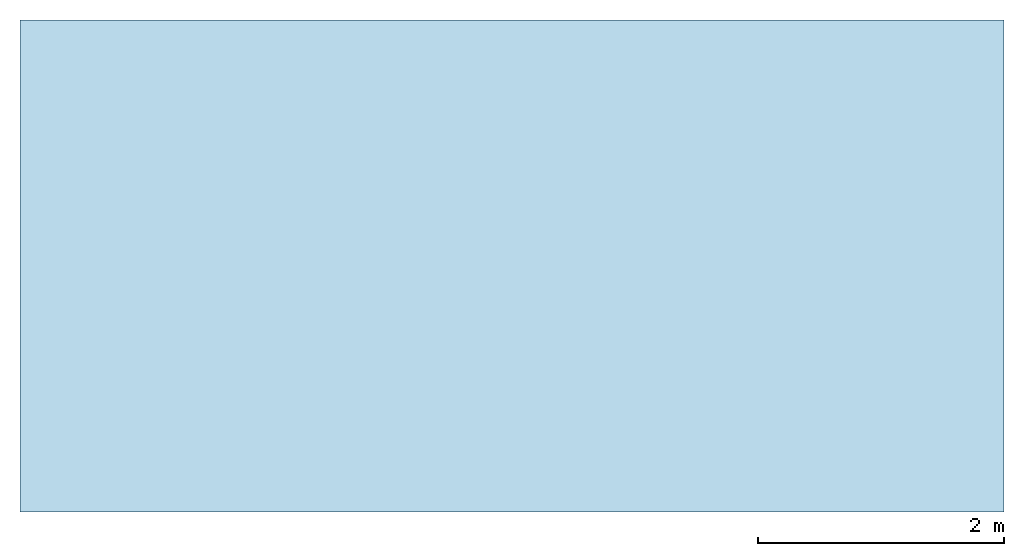
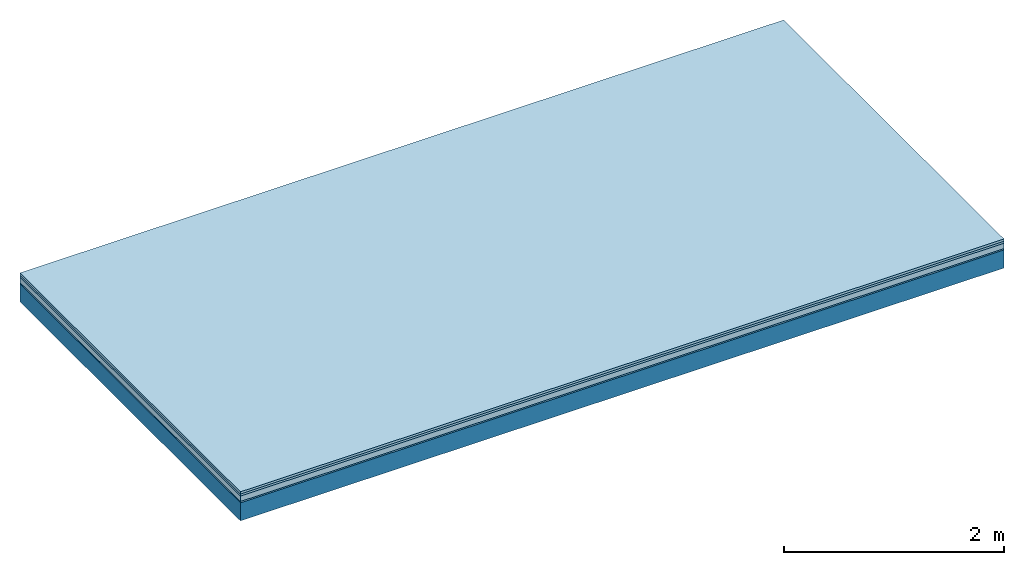
# One storey: 4 plates, 1 member, 1 element without a shape of its own.
"""IFC4 building model written with IfcOpenShell, lengths in metres."""

from ifc_helpers import new_model, si_unit, derived_unit, direction, frame, frame_2d, origin, origin_with_axes, place, context, project, spatial, rectangle, extrude, material, layer, layer_set, type_object, element, aggregate, save


model = new_model("IFC4")

# Units and contexts
plan_context = context("Plan", 3, precision=1e-05, world=origin(), true_north=direction((0.0, 1.0)))
model_context = context("Model", 3, precision=1e-05, world=origin(), true_north=direction((0.0, 1.0)))
ifc_project = project(units=[si_unit("LENGTHUNIT", "METRE"), derived_unit("SOUNDPRESSUREUNIT", [(si_unit("PRESSUREUNIT", "PASCAL", prefix="MICRO"), 0)]), si_unit("ENERGYUNIT", "JOULE", prefix="MEGA"), si_unit("MASSUNIT", "GRAM", prefix="KILO"), derived_unit("THERMALTRANSMITTANCEUNIT", [(si_unit("POWERUNIT", "WATT"), 1), (si_unit("AREAUNIT", "SQUARE_METRE"), -1), (si_unit("THERMODYNAMICTEMPERATUREUNIT", "KELVIN"), -1)]), derived_unit("AREADENSITYUNIT", [(si_unit("MASSUNIT", "GRAM", prefix="KILO"), 1), (si_unit("AREAUNIT", "SQUARE_METRE"), -1)]), derived_unit("USERDEFINED", [(si_unit("ENERGYUNIT", "JOULE", prefix="MEGA"), 1), (si_unit("AREAUNIT", "SQUARE_METRE"), -1)])], contexts=[plan_context, model_context])

# Site, building, storey
site = spatial("IfcSite", under=ifc_project)
building_placement = place(None, origin())
building = spatial("IfcBuilding", under=site, at=building_placement)
storey_placement = place(building_placement, origin())
storey = spatial("IfcBuildingStorey", under=building, at=storey_placement)

# Slab, member, plates
ifc_material_1 = material(Name="Floor heating system Therm38 longitudinal", Category="03.007")
ifc_layer_1 = layer(ifc_material_1, 0.025, Name="On-material")
ifc_material_2 = material(Category="10.009")
ifc_layer_2 = layer(ifc_material_2, 0.022, Name="Impact sound insulation")
ifc_material_3 = material(Category="03.011")
ifc_layer_3 = layer(ifc_material_3, 0.06, Name="on Supporting structure")
ifc_material_4 = material(Category="03.007")
ifc_layer_4 = layer(ifc_material_4, 0.015, Name="Sub-floor")
ifc_material_5 = material(Name="of the art")
ifc_layer_5 = layer(ifc_material_5, 0.0, Name="Bond")
ifc_layer_6 = layer(None, 0.2, Name="Supporting structure")
ifc_layer_set = layer_set([ifc_layer_1, ifc_layer_2, ifc_layer_3, ifc_layer_4, ifc_layer_5, ifc_layer_6])
slab_type = type_object("IfcSlabType", Name="A1096", PredefinedType="NOTDEFINED", material=ifc_layer_set)
slab_placement = place(None, frame((0.0, 0.0, 0.0), z_axis=(0.0, 0.0, -1.0), x_axis=(1.0, 0.0, 0.0)))
slab = element("IfcSlab", 1, at=slab_placement, inside=storey, type_object=slab_type, material=ifc_layer_set, Name="Slab #1")
ifc_material_6 = material()
member_placement = place(slab_placement, origin())
member = element("IfcMember", 2, at=member_placement, material=ifc_material_6, Name="Supporting structure", context=plan_context, shape_type="SweptSolid", body=[
    extrude(rectangle(XDim=1.0, YDim=0.2, at=frame_2d((0.5, 0.1), x_axis=(1.0, 0.0))), frame((0.0, 4.0, 0.122), z_axis=(0.0, -1.0, 0.0), x_axis=(1.0, 0.0, 0.0)), (0.0, 0.0, 1.0), 4.0),
    extrude(rectangle(XDim=1.0, YDim=0.2, at=frame_2d((0.5, 0.1), x_axis=(1.0, 0.0))), frame((1.0, 4.0, 0.122), z_axis=(0.0, -1.0, 0.0), x_axis=(1.0, 0.0, 0.0)), (0.0, 0.0, 1.0), 4.0),
    extrude(rectangle(XDim=1.0, YDim=0.2, at=frame_2d((0.5, 0.1), x_axis=(1.0, 0.0))), frame((2.0, 4.0, 0.122), z_axis=(0.0, -1.0, 0.0), x_axis=(1.0, 0.0, 0.0)), (0.0, 0.0, 1.0), 4.0),
    extrude(rectangle(XDim=1.0, YDim=0.2, at=frame_2d((0.5, 0.1), x_axis=(1.0, 0.0))), frame((3.0, 4.0, 0.122), z_axis=(0.0, -1.0, 0.0), x_axis=(1.0, 0.0, 0.0)), (0.0, 0.0, 1.0), 4.0),
    extrude(rectangle(XDim=1.0, YDim=0.2, at=frame_2d((0.5, 0.1), x_axis=(1.0, 0.0))), frame((4.0, 4.0, 0.122), z_axis=(0.0, -1.0, 0.0), x_axis=(1.0, 0.0, 0.0)), (0.0, 0.0, 1.0), 4.0),
    extrude(rectangle(XDim=1.0, YDim=0.2, at=frame_2d((0.5, 0.1), x_axis=(1.0, 0.0))), frame((5.0, 4.0, 0.122), z_axis=(0.0, -1.0, 0.0), x_axis=(1.0, 0.0, 0.0)), (0.0, 0.0, 1.0), 4.0),
    extrude(rectangle(XDim=1.0, YDim=0.2, at=frame_2d((0.5, 0.1), x_axis=(1.0, 0.0))), frame((6.0, 4.0, 0.122), z_axis=(0.0, -1.0, 0.0), x_axis=(1.0, 0.0, 0.0)), (0.0, 0.0, 1.0), 4.0),
    extrude(rectangle(XDim=1.0, YDim=0.2, at=frame_2d((0.5, 0.1), x_axis=(1.0, 0.0))), frame((7.0, 4.0, 0.122), z_axis=(0.0, -1.0, 0.0), x_axis=(1.0, 0.0, 0.0)), (0.0, 0.0, 1.0), 4.0),
])
plate_1_placement = place(slab_placement, origin())
plate_1 = element("IfcPlate", 3, at=plate_1_placement, material=ifc_material_1, Name="On-material", context=plan_context, shape_type="SweptSolid", body=[
    extrude(rectangle(XDim=8.0, YDim=4.0, at=frame_2d((4.0, 2.0), x_axis=(1.0, 0.0))), origin_with_axes(), (0.0, 0.0, 1.0), 0.025),
])
plate_2_placement = place(slab_placement, origin())
plate_2 = element("IfcPlate", 4, at=plate_2_placement, material=ifc_material_2, Name="Impact sound insulation", context=plan_context, shape_type="SweptSolid", body=[
    extrude(rectangle(XDim=8.0, YDim=4.0, at=frame_2d((4.0, 2.0), x_axis=(1.0, 0.0))), frame((0.0, 0.0, 0.025), z_axis=(0.0, 0.0, 1.0), x_axis=(1.0, 0.0, 0.0)), (0.0, 0.0, 1.0), 0.022),
])
plate_3_placement = place(slab_placement, origin())
plate_3 = element("IfcPlate", 5, at=plate_3_placement, material=ifc_material_3, Name="on Supporting structure", context=plan_context, shape_type="SweptSolid", body=[
    extrude(rectangle(XDim=8.0, YDim=4.0, at=frame_2d((4.0, 2.0), x_axis=(1.0, 0.0))), frame((0.0, 0.0, 0.047), z_axis=(0.0, 0.0, 1.0), x_axis=(1.0, 0.0, 0.0)), (0.0, 0.0, 1.0), 0.06),
])
plate_4_placement = place(slab_placement, origin())
plate_4 = element("IfcPlate", 6, at=plate_4_placement, material=ifc_material_4, Name="Sub-floor", context=plan_context, shape_type="SweptSolid", body=[
    extrude(rectangle(XDim=8.0, YDim=4.0, at=frame_2d((4.0, 2.0), x_axis=(1.0, 0.0))), frame((0.0, 0.0, 0.107), z_axis=(0.0, 0.0, 1.0), x_axis=(1.0, 0.0, 0.0)), (0.0, 0.0, 1.0), 0.015),
])
aggregate(slab, [plate_1, plate_2, plate_3, plate_4, member])

save(model, "model.ifc")
